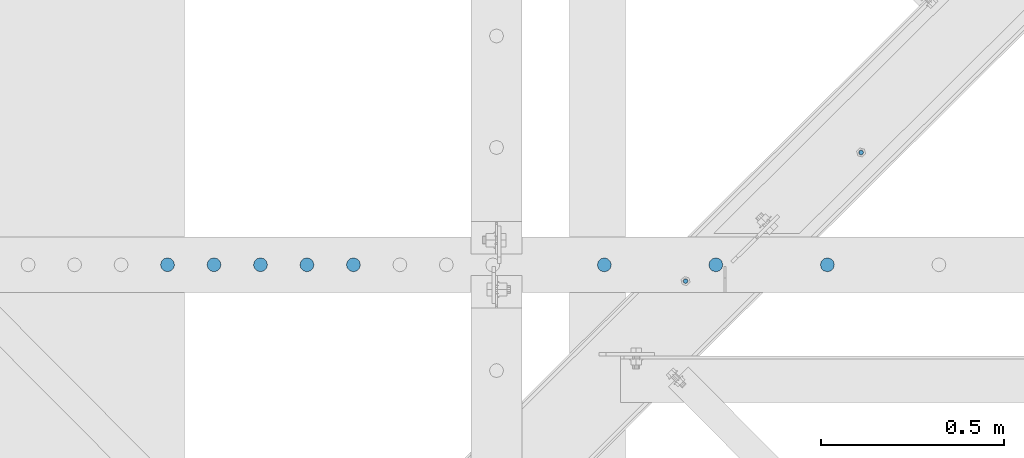
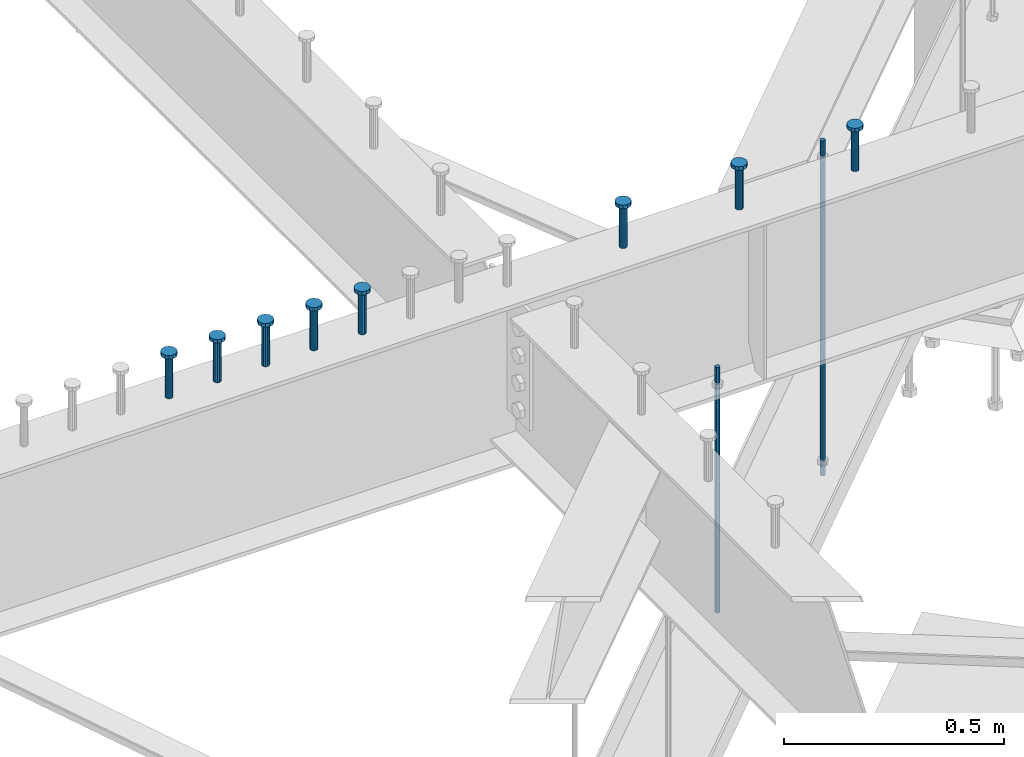
# One storey, part 207 of 975: 10 columns.
"""IFC2X3 building model written with IfcOpenShell, lengths in millimetres."""

from ifc_helpers import new_model, si_unit, frame, origin_with_axes, place, context, subcontext, project, spatial, faceted_brep, material, type_object, element, save


model = new_model("IFC2X3")

# Units and contexts
model_context = context("Model", 3, precision=1e-05, world=origin_with_axes())
body_context = subcontext(model_context, "Body", "Model", "MODEL_VIEW")
ifc_project = project(units=[si_unit("LENGTHUNIT", "METRE", prefix="MILLI"), si_unit("AREAUNIT", "SQUARE_METRE"), si_unit("VOLUMEUNIT", "CUBIC_METRE"), si_unit("MASSUNIT", "GRAM", prefix="KILO"), si_unit("TIMEUNIT", "SECOND"), si_unit("PLANEANGLEUNIT", "RADIAN"), si_unit("SOLIDANGLEUNIT", "STERADIAN"), si_unit("THERMODYNAMICTEMPERATUREUNIT", "DEGREE_CELSIUS"), si_unit("LUMINOUSINTENSITYUNIT", "LUMEN")], contexts=[model_context])

# Site, building, storey
site_placement = place(None, origin_with_axes())
site = spatial("IfcSite", under=ifc_project, at=site_placement, CompositionType="ELEMENT")
building_placement = place(site_placement, origin_with_axes())
building = spatial("IfcBuilding", under=site, at=building_placement, Name="Undefined", CompositionType="ELEMENT")
storey_placement = place(building_placement, origin_with_axes())
storey = spatial("IfcBuildingStorey", under=building, at=storey_placement, Name="Undefined", CompositionType="ELEMENT", Elevation=0.0)

# Columns
ifc_material_1 = material(Name="STEEL/A36")
column_type_1 = type_object("IfcColumnType", PredefinedType="NOTDEFINED")
column_1_placement = place(storey_placement, frame((27641.2127151628, 13699.1792456856, 2870.2), z_axis=(-0.705007718837806, 0.709199630836842, 0.0), x_axis=(0.0, 0.0, 1.0)))
element("IfcColumn", 1, at=column_1_placement, inside=storey, type_object=column_type_1, material=ifc_material_1, Name="ALL-THREAD ROD", context=body_context, shape_type="Brep", body=[
    faceted_brep([(0.0, -6.34999999998763, -3.63797880709171e-12), (0.0, -4.49012806052269, -4.49012806054634), (931.8625, -4.49012806052269, -4.49012806054634), (931.8625, -6.34999999998763, -3.63797880709171e-12), (0.0, 7.27595761418343e-12, -6.35000000000764), (931.8625, 7.27595761418343e-12, -6.35000000000764), (0.0, 4.49012806053724, -4.49012806053906), (931.8625, 4.49012806053724, -4.49012806053906), (0.0, 6.34999999999491, 5.45696821063757e-12), (931.8625, 6.34999999999491, 5.45696821063757e-12), (0.0, 4.49012806052633, 4.49012806054634), (931.8625, 4.49012806052633, 4.49012806054634), (0.0, 0.0, 6.35000000000764), (931.8625, 0.0, 6.35000000000764), (0.0, -4.49012806053361, 4.49012806053543), (931.8625, -4.49012806053361, 4.49012806053543)], [[[0, 1, 2, 3]], [[1, 4, 5, 2]], [[4, 6, 7, 5]], [[6, 8, 9, 7]], [[8, 10, 11, 9]], [[10, 12, 13, 11]], [[12, 14, 15, 13]], [[14, 0, 3, 15]], [[5, 7, 9, 11, 13, 15, 3, 2]], [[14, 12, 10, 8, 6, 4, 1, 0]]]),
])
column_2_placement = place(storey_placement, frame((27161.5007166304, 13347.70000005, 2870.2), z_axis=(-0.705007718837806, 0.709199630836842, 0.0), x_axis=(0.0, 0.0, 1.0)))
element("IfcColumn", 2, at=column_2_placement, inside=storey, type_object=column_type_1, material=ifc_material_1, Name="ALL-THREAD ROD", context=body_context, shape_type="Brep", body=[
    faceted_brep([(0.0, -6.34999999998763, -3.63797880709171e-12), (0.0, -4.49012806052269, -4.49012806054634), (682.625, -4.49012806052633, -4.49012806054816), (682.625, -6.34999999999491, -5.45696821063757e-12), (0.0, 7.27595761418343e-12, -6.35000000000764), (682.625, 7.27595761418343e-12, -6.35000000000764), (0.0, 4.49012806053724, -4.49012806053906), (682.625, 4.49012806053361, -4.49012806054088), (0.0, 6.34999999999491, 5.45696821063757e-12), (682.625, 6.34999999999127, 3.63797880709171e-12), (0.0, 4.49012806052633, 4.49012806054634), (682.625, 4.49012806052633, 4.49012806054634), (0.0, 0.0, 6.35000000000764), (682.625, -7.27595761418343e-12, 6.35000000000764), (0.0, -4.49012806053361, 4.49012806053543), (682.625, -4.49012806053361, 4.49012806053543)], [[[0, 1, 2, 3]], [[1, 4, 5, 2]], [[4, 6, 7, 5]], [[6, 8, 9, 7]], [[8, 10, 11, 9]], [[10, 12, 13, 11]], [[12, 14, 15, 13]], [[14, 0, 3, 15]], [[5, 7, 9, 11, 13, 15, 3, 2]], [[14, 12, 10, 8, 6, 4, 1, 0]]]),
])
ifc_material_2 = material(Name="STEEL/A108")
column_type_2 = type_object("IfcColumnType", Name="STUD_3/4-DIA", PredefinedType="NOTDEFINED")
column_3_placement = place(storey_placement, frame((27548.9459584101, 13392.15, 3937.0), z_axis=(0.0, 1.0, 0.0), x_axis=(0.0, 0.0, 1.0)))
element("IfcColumn", 3, at=column_3_placement, inside=storey, type_object=column_type_2, material=ifc_material_2, ObjectType="STUD_3/4-DIA", context=body_context, shape_type="Brep", body=[
    faceted_brep([(0.0, -9.52000045776367, 0.0), (0.0, -8.25, -4.76000022888184), (115.57, -8.25, -4.76000022888184), (115.57, -9.52000045776367, 0.0), (0.0, -4.76000022888184, -8.25), (115.57, -4.76000022888184, -8.25), (0.0, 0.0, -9.52000045776367), (115.57, 0.0, -9.52000045776367), (0.0, 4.76000022888184, -8.25), (115.57, 4.76000022888184, -8.25), (0.0, 8.25, -4.76000022888184), (115.57, 8.25, -4.76000022888184), (0.0, 9.52000045776367, 0.0), (115.57, 9.52000045776367, 0.0), (0.0, 8.25, 4.76000022888184), (115.57, 8.25, 4.76000022888184), (0.0, 4.76000022888184, 8.25), (115.57, 4.76000022888184, 8.25), (0.0, 0.0, 9.52000045776367), (115.57, 0.0, 9.52000045776367), (0.0, -4.76000022888184, 8.25), (115.57, -4.76000022888184, 8.25), (0.0, -8.25, 4.76000022888184), (115.57, -8.25, 4.76000022888184), (116.84, -16.5, -9.52000045776367), (116.84, -19.0499992370605, 0.0), (116.84, -9.52000045776367, -16.5), (116.84, 0.0, -19.0499992370605), (116.84, 9.52000045776367, -16.5), (116.84, 16.5, -9.52000045776367), (116.84, 19.0499992370605, 0.0), (116.84, 16.5, 9.52000045776367), (116.84, 9.52000045776367, 16.5), (116.84, 0.0, 19.0499992370605), (116.84, -9.52000045776367, 16.5), (116.84, -16.5, 9.52000045776367), (127.0, -16.5, -9.52000045776367), (127.0, -19.0499992370605, 0.0), (127.0, -9.52000045776367, -16.5), (127.0, 0.0, -19.0499992370605), (127.0, 9.52000045776367, -16.5), (127.0, 16.5, -9.52000045776367), (127.0, 19.0499992370605, 0.0), (127.0, 16.5, 9.52000045776367), (127.0, 9.52000045776367, 16.5), (127.0, 0.0, 19.0499992370605), (127.0, -9.52000045776367, 16.5), (127.0, -16.5, 9.52000045776367)], [[[0, 1, 2, 3]], [[1, 4, 5, 2]], [[4, 6, 7, 5]], [[6, 8, 9, 7]], [[8, 10, 11, 9]], [[10, 12, 13, 11]], [[12, 14, 15, 13]], [[14, 16, 17, 15]], [[16, 18, 19, 17]], [[18, 20, 21, 19]], [[20, 22, 23, 21]], [[22, 0, 3, 23]], [[22, 20, 18, 16, 14, 12, 10, 8, 6, 4, 1, 0]], [[3, 2, 24, 25]], [[2, 5, 26, 24]], [[5, 7, 27, 26]], [[7, 9, 28, 27]], [[9, 11, 29, 28]], [[11, 13, 30, 29]], [[13, 15, 31, 30]], [[15, 17, 32, 31]], [[17, 19, 33, 32]], [[19, 21, 34, 33]], [[21, 23, 35, 34]], [[23, 3, 25, 35]], [[25, 24, 36, 37]], [[24, 26, 38, 36]], [[26, 27, 39, 38]], [[27, 28, 40, 39]], [[28, 29, 41, 40]], [[29, 30, 42, 41]], [[30, 31, 43, 42]], [[31, 32, 44, 43]], [[32, 33, 45, 44]], [[33, 34, 46, 45]], [[34, 35, 47, 46]], [[35, 25, 37, 47]], [[38, 39, 40, 41, 42, 43, 44, 45, 46, 47, 37, 36]]]),
])
column_4_placement = place(storey_placement, frame((27244.1459584101, 13392.15, 3937.0), z_axis=(0.0, 1.0, 0.0), x_axis=(0.0, 0.0, 1.0)))
element("IfcColumn", 4, at=column_4_placement, inside=storey, type_object=column_type_2, material=ifc_material_2, ObjectType="STUD_3/4-DIA", context=body_context, shape_type="Brep", body=[
    faceted_brep([(0.0, -9.52000045776367, 0.0), (0.0, -8.25, -4.76000022888184), (115.57, -8.25, -4.76000022888184), (115.57, -9.52000045776367, 0.0), (0.0, -4.76000022888184, -8.25), (115.57, -4.76000022888184, -8.25), (0.0, 0.0, -9.52000045776367), (115.57, 0.0, -9.52000045776367), (0.0, 4.76000022888184, -8.25), (115.57, 4.76000022888184, -8.25), (0.0, 8.25, -4.76000022888184), (115.57, 8.25, -4.76000022888184), (0.0, 9.52000045776367, 0.0), (115.57, 9.52000045776367, 0.0), (0.0, 8.25, 4.76000022888184), (115.57, 8.25, 4.76000022888184), (0.0, 4.76000022888184, 8.25), (115.57, 4.76000022888184, 8.25), (0.0, 0.0, 9.52000045776367), (115.57, 0.0, 9.52000045776367), (0.0, -4.76000022888184, 8.25), (115.57, -4.76000022888184, 8.25), (0.0, -8.25, 4.76000022888184), (115.57, -8.25, 4.76000022888184), (116.84, -16.5, -9.52000045776367), (116.84, -19.0499992370605, 0.0), (116.84, -9.52000045776367, -16.5), (116.84, 0.0, -19.0499992370605), (116.84, 9.52000045776367, -16.5), (116.84, 16.5, -9.52000045776367), (116.84, 19.0499992370605, 0.0), (116.84, 16.5, 9.52000045776367), (116.84, 9.52000045776367, 16.5), (116.84, 0.0, 19.0499992370605), (116.84, -9.52000045776367, 16.5), (116.84, -16.5, 9.52000045776367), (127.0, -16.5, -9.52000045776367), (127.0, -19.0499992370605, 0.0), (127.0, -9.52000045776367, -16.5), (127.0, 0.0, -19.0499992370605), (127.0, 9.52000045776367, -16.5), (127.0, 16.5, -9.52000045776367), (127.0, 19.0499992370605, 0.0), (127.0, 16.5, 9.52000045776367), (127.0, 9.52000045776367, 16.5), (127.0, 0.0, 19.0499992370605), (127.0, -9.52000045776367, 16.5), (127.0, -16.5, 9.52000045776367)], [[[0, 1, 2, 3]], [[1, 4, 5, 2]], [[4, 6, 7, 5]], [[6, 8, 9, 7]], [[8, 10, 11, 9]], [[10, 12, 13, 11]], [[12, 14, 15, 13]], [[14, 16, 17, 15]], [[16, 18, 19, 17]], [[18, 20, 21, 19]], [[20, 22, 23, 21]], [[22, 0, 3, 23]], [[22, 20, 18, 16, 14, 12, 10, 8, 6, 4, 1, 0]], [[3, 2, 24, 25]], [[2, 5, 26, 24]], [[5, 7, 27, 26]], [[7, 9, 28, 27]], [[9, 11, 29, 28]], [[11, 13, 30, 29]], [[13, 15, 31, 30]], [[15, 17, 32, 31]], [[17, 19, 33, 32]], [[19, 21, 34, 33]], [[21, 23, 35, 34]], [[23, 3, 25, 35]], [[25, 24, 36, 37]], [[24, 26, 38, 36]], [[26, 27, 39, 38]], [[27, 28, 40, 39]], [[28, 29, 41, 40]], [[29, 30, 42, 41]], [[30, 31, 43, 42]], [[31, 32, 44, 43]], [[32, 33, 45, 44]], [[33, 34, 46, 45]], [[34, 35, 47, 46]], [[35, 25, 37, 47]], [[38, 39, 40, 41, 42, 43, 44, 45, 46, 47, 37, 36]]]),
])
column_5_placement = place(storey_placement, frame((26939.3459584101, 13392.15, 3937.0), z_axis=(0.0, 1.0, 0.0), x_axis=(0.0, 0.0, 1.0)))
element("IfcColumn", 5, at=column_5_placement, inside=storey, type_object=column_type_2, material=ifc_material_2, ObjectType="STUD_3/4-DIA", context=body_context, shape_type="Brep", body=[
    faceted_brep([(0.0, -9.52000045776367, 0.0), (0.0, -8.25, -4.76000022888184), (115.57, -8.25, -4.76000022888184), (115.57, -9.52000045776367, 0.0), (0.0, -4.76000022888184, -8.25), (115.57, -4.76000022888184, -8.25), (0.0, 0.0, -9.52000045776367), (115.57, 0.0, -9.52000045776367), (0.0, 4.76000022888184, -8.25), (115.57, 4.76000022888184, -8.25), (0.0, 8.25, -4.76000022888184), (115.57, 8.25, -4.76000022888184), (0.0, 9.52000045776367, 0.0), (115.57, 9.52000045776367, 0.0), (0.0, 8.25, 4.76000022888184), (115.57, 8.25, 4.76000022888184), (0.0, 4.76000022888184, 8.25), (115.57, 4.76000022888184, 8.25), (0.0, 0.0, 9.52000045776367), (115.57, 0.0, 9.52000045776367), (0.0, -4.76000022888184, 8.25), (115.57, -4.76000022888184, 8.25), (0.0, -8.25, 4.76000022888184), (115.57, -8.25, 4.76000022888184), (116.84, -16.5, -9.52000045776367), (116.84, -19.0499992370605, 0.0), (116.84, -9.52000045776367, -16.5), (116.84, 0.0, -19.0499992370605), (116.84, 9.52000045776367, -16.5), (116.84, 16.5, -9.52000045776367), (116.84, 19.0499992370605, 0.0), (116.84, 16.5, 9.52000045776367), (116.84, 9.52000045776367, 16.5), (116.84, 0.0, 19.0499992370605), (116.84, -9.52000045776367, 16.5), (116.84, -16.5, 9.52000045776367), (127.0, -16.5, -9.52000045776367), (127.0, -19.0499992370605, 0.0), (127.0, -9.52000045776367, -16.5), (127.0, 0.0, -19.0499992370605), (127.0, 9.52000045776367, -16.5), (127.0, 16.5, -9.52000045776367), (127.0, 19.0499992370605, 0.0), (127.0, 16.5, 9.52000045776367), (127.0, 9.52000045776367, 16.5), (127.0, 0.0, 19.0499992370605), (127.0, -9.52000045776367, 16.5), (127.0, -16.5, 9.52000045776367)], [[[0, 1, 2, 3]], [[1, 4, 5, 2]], [[4, 6, 7, 5]], [[6, 8, 9, 7]], [[8, 10, 11, 9]], [[10, 12, 13, 11]], [[12, 14, 15, 13]], [[14, 16, 17, 15]], [[16, 18, 19, 17]], [[18, 20, 21, 19]], [[20, 22, 23, 21]], [[22, 0, 3, 23]], [[22, 20, 18, 16, 14, 12, 10, 8, 6, 4, 1, 0]], [[3, 2, 24, 25]], [[2, 5, 26, 24]], [[5, 7, 27, 26]], [[7, 9, 28, 27]], [[9, 11, 29, 28]], [[11, 13, 30, 29]], [[13, 15, 31, 30]], [[15, 17, 32, 31]], [[17, 19, 33, 32]], [[19, 21, 34, 33]], [[21, 23, 35, 34]], [[23, 3, 25, 35]], [[25, 24, 36, 37]], [[24, 26, 38, 36]], [[26, 27, 39, 38]], [[27, 28, 40, 39]], [[28, 29, 41, 40]], [[29, 30, 42, 41]], [[30, 31, 43, 42]], [[31, 32, 44, 43]], [[32, 33, 45, 44]], [[33, 34, 46, 45]], [[34, 35, 47, 46]], [[35, 25, 37, 47]], [[38, 39, 40, 41, 42, 43, 44, 45, 46, 47, 37, 36]]]),
])
column_6_placement = place(storey_placement, frame((26253.5459584101, 13392.15, 3937.0), z_axis=(0.0, 1.0, 0.0), x_axis=(0.0, 0.0, 1.0)))
element("IfcColumn", 6, at=column_6_placement, inside=storey, type_object=column_type_2, material=ifc_material_2, ObjectType="STUD_3/4-DIA", context=body_context, shape_type="Brep", body=[
    faceted_brep([(0.0, -9.52000045776367, 0.0), (0.0, -8.25, -4.76000022888184), (115.57, -8.25, -4.76000022888184), (115.57, -9.52000045776367, 0.0), (0.0, -4.76000022888184, -8.25), (115.57, -4.76000022888184, -8.25), (0.0, 0.0, -9.52000045776367), (115.57, 0.0, -9.52000045776367), (0.0, 4.76000022888184, -8.25), (115.57, 4.76000022888184, -8.25), (0.0, 8.25, -4.76000022888184), (115.57, 8.25, -4.76000022888184), (0.0, 9.52000045776367, 0.0), (115.57, 9.52000045776367, 0.0), (0.0, 8.25, 4.76000022888184), (115.57, 8.25, 4.76000022888184), (0.0, 4.76000022888184, 8.25), (115.57, 4.76000022888184, 8.25), (0.0, 0.0, 9.52000045776367), (115.57, 0.0, 9.52000045776367), (0.0, -4.76000022888184, 8.25), (115.57, -4.76000022888184, 8.25), (0.0, -8.25, 4.76000022888184), (115.57, -8.25, 4.76000022888184), (116.84, -16.5, -9.52000045776367), (116.84, -19.0499992370605, 0.0), (116.84, -9.52000045776367, -16.5), (116.84, 0.0, -19.0499992370605), (116.84, 9.52000045776367, -16.5), (116.84, 16.5, -9.52000045776367), (116.84, 19.0499992370605, 0.0), (116.84, 16.5, 9.52000045776367), (116.84, 9.52000045776367, 16.5), (116.84, 0.0, 19.0499992370605), (116.84, -9.52000045776367, 16.5), (116.84, -16.5, 9.52000045776367), (127.0, -16.5, -9.52000045776367), (127.0, -19.0499992370605, 0.0), (127.0, -9.52000045776367, -16.5), (127.0, 0.0, -19.0499992370605), (127.0, 9.52000045776367, -16.5), (127.0, 16.5, -9.52000045776367), (127.0, 19.0499992370605, 0.0), (127.0, 16.5, 9.52000045776367), (127.0, 9.52000045776367, 16.5), (127.0, 0.0, 19.0499992370605), (127.0, -9.52000045776367, 16.5), (127.0, -16.5, 9.52000045776367)], [[[0, 1, 2, 3]], [[1, 4, 5, 2]], [[4, 6, 7, 5]], [[6, 8, 9, 7]], [[8, 10, 11, 9]], [[10, 12, 13, 11]], [[12, 14, 15, 13]], [[14, 16, 17, 15]], [[16, 18, 19, 17]], [[18, 20, 21, 19]], [[20, 22, 23, 21]], [[22, 0, 3, 23]], [[22, 20, 18, 16, 14, 12, 10, 8, 6, 4, 1, 0]], [[3, 2, 24, 25]], [[2, 5, 26, 24]], [[5, 7, 27, 26]], [[7, 9, 28, 27]], [[9, 11, 29, 28]], [[11, 13, 30, 29]], [[13, 15, 31, 30]], [[15, 17, 32, 31]], [[17, 19, 33, 32]], [[19, 21, 34, 33]], [[21, 23, 35, 34]], [[23, 3, 25, 35]], [[25, 24, 36, 37]], [[24, 26, 38, 36]], [[26, 27, 39, 38]], [[27, 28, 40, 39]], [[28, 29, 41, 40]], [[29, 30, 42, 41]], [[30, 31, 43, 42]], [[31, 32, 44, 43]], [[32, 33, 45, 44]], [[33, 34, 46, 45]], [[34, 35, 47, 46]], [[35, 25, 37, 47]], [[38, 39, 40, 41, 42, 43, 44, 45, 46, 47, 37, 36]]]),
])
column_7_placement = place(storey_placement, frame((26126.5459584101, 13392.15, 3937.0), z_axis=(0.0, 1.0, 0.0), x_axis=(0.0, 0.0, 1.0)))
element("IfcColumn", 7, at=column_7_placement, inside=storey, type_object=column_type_2, material=ifc_material_2, ObjectType="STUD_3/4-DIA", context=body_context, shape_type="Brep", body=[
    faceted_brep([(0.0, -9.52000045776367, 0.0), (0.0, -8.25, -4.76000022888184), (115.57, -8.25, -4.76000022888184), (115.57, -9.52000045776367, 0.0), (0.0, -4.76000022888184, -8.25), (115.57, -4.76000022888184, -8.25), (0.0, 0.0, -9.52000045776367), (115.57, 0.0, -9.52000045776367), (0.0, 4.76000022888184, -8.25), (115.57, 4.76000022888184, -8.25), (0.0, 8.25, -4.76000022888184), (115.57, 8.25, -4.76000022888184), (0.0, 9.52000045776367, 0.0), (115.57, 9.52000045776367, 0.0), (0.0, 8.25, 4.76000022888184), (115.57, 8.25, 4.76000022888184), (0.0, 4.76000022888184, 8.25), (115.57, 4.76000022888184, 8.25), (0.0, 0.0, 9.52000045776367), (115.57, 0.0, 9.52000045776367), (0.0, -4.76000022888184, 8.25), (115.57, -4.76000022888184, 8.25), (0.0, -8.25, 4.76000022888184), (115.57, -8.25, 4.76000022888184), (116.84, -16.5, -9.52000045776367), (116.84, -19.0499992370605, 0.0), (116.84, -9.52000045776367, -16.5), (116.84, 0.0, -19.0499992370605), (116.84, 9.52000045776367, -16.5), (116.84, 16.5, -9.52000045776367), (116.84, 19.0499992370605, 0.0), (116.84, 16.5, 9.52000045776367), (116.84, 9.52000045776367, 16.5), (116.84, 0.0, 19.0499992370605), (116.84, -9.52000045776367, 16.5), (116.84, -16.5, 9.52000045776367), (127.0, -16.5, -9.52000045776367), (127.0, -19.0499992370605, 0.0), (127.0, -9.52000045776367, -16.5), (127.0, 0.0, -19.0499992370605), (127.0, 9.52000045776367, -16.5), (127.0, 16.5, -9.52000045776367), (127.0, 19.0499992370605, 0.0), (127.0, 16.5, 9.52000045776367), (127.0, 9.52000045776367, 16.5), (127.0, 0.0, 19.0499992370605), (127.0, -9.52000045776367, 16.5), (127.0, -16.5, 9.52000045776367)], [[[0, 1, 2, 3]], [[1, 4, 5, 2]], [[4, 6, 7, 5]], [[6, 8, 9, 7]], [[8, 10, 11, 9]], [[10, 12, 13, 11]], [[12, 14, 15, 13]], [[14, 16, 17, 15]], [[16, 18, 19, 17]], [[18, 20, 21, 19]], [[20, 22, 23, 21]], [[22, 0, 3, 23]], [[22, 20, 18, 16, 14, 12, 10, 8, 6, 4, 1, 0]], [[3, 2, 24, 25]], [[2, 5, 26, 24]], [[5, 7, 27, 26]], [[7, 9, 28, 27]], [[9, 11, 29, 28]], [[11, 13, 30, 29]], [[13, 15, 31, 30]], [[15, 17, 32, 31]], [[17, 19, 33, 32]], [[19, 21, 34, 33]], [[21, 23, 35, 34]], [[23, 3, 25, 35]], [[25, 24, 36, 37]], [[24, 26, 38, 36]], [[26, 27, 39, 38]], [[27, 28, 40, 39]], [[28, 29, 41, 40]], [[29, 30, 42, 41]], [[30, 31, 43, 42]], [[31, 32, 44, 43]], [[32, 33, 45, 44]], [[33, 34, 46, 45]], [[34, 35, 47, 46]], [[35, 25, 37, 47]], [[38, 39, 40, 41, 42, 43, 44, 45, 46, 47, 37, 36]]]),
])
column_8_placement = place(storey_placement, frame((25999.5459584101, 13392.15, 3937.0), z_axis=(0.0, 1.0, 0.0), x_axis=(0.0, 0.0, 1.0)))
element("IfcColumn", 8, at=column_8_placement, inside=storey, type_object=column_type_2, material=ifc_material_2, ObjectType="STUD_3/4-DIA", context=body_context, shape_type="Brep", body=[
    faceted_brep([(0.0, -9.52000045776367, 0.0), (0.0, -8.25, -4.76000022888184), (115.57, -8.25, -4.76000022888184), (115.57, -9.52000045776367, 0.0), (0.0, -4.76000022888184, -8.25), (115.57, -4.76000022888184, -8.25), (0.0, 0.0, -9.52000045776367), (115.57, 0.0, -9.52000045776367), (0.0, 4.76000022888184, -8.25), (115.57, 4.76000022888184, -8.25), (0.0, 8.25, -4.76000022888184), (115.57, 8.25, -4.76000022888184), (0.0, 9.52000045776367, 0.0), (115.57, 9.52000045776367, 0.0), (0.0, 8.25, 4.76000022888184), (115.57, 8.25, 4.76000022888184), (0.0, 4.76000022888184, 8.25), (115.57, 4.76000022888184, 8.25), (0.0, 0.0, 9.52000045776367), (115.57, 0.0, 9.52000045776367), (0.0, -4.76000022888184, 8.25), (115.57, -4.76000022888184, 8.25), (0.0, -8.25, 4.76000022888184), (115.57, -8.25, 4.76000022888184), (116.84, -16.5, -9.52000045776367), (116.84, -19.0499992370605, 0.0), (116.84, -9.52000045776367, -16.5), (116.84, 0.0, -19.0499992370605), (116.84, 9.52000045776367, -16.5), (116.84, 16.5, -9.52000045776367), (116.84, 19.0499992370605, 0.0), (116.84, 16.5, 9.52000045776367), (116.84, 9.52000045776367, 16.5), (116.84, 0.0, 19.0499992370605), (116.84, -9.52000045776367, 16.5), (116.84, -16.5, 9.52000045776367), (127.0, -16.5, -9.52000045776367), (127.0, -19.0499992370605, 0.0), (127.0, -9.52000045776367, -16.5), (127.0, 0.0, -19.0499992370605), (127.0, 9.52000045776367, -16.5), (127.0, 16.5, -9.52000045776367), (127.0, 19.0499992370605, 0.0), (127.0, 16.5, 9.52000045776367), (127.0, 9.52000045776367, 16.5), (127.0, 0.0, 19.0499992370605), (127.0, -9.52000045776367, 16.5), (127.0, -16.5, 9.52000045776367)], [[[0, 1, 2, 3]], [[1, 4, 5, 2]], [[4, 6, 7, 5]], [[6, 8, 9, 7]], [[8, 10, 11, 9]], [[10, 12, 13, 11]], [[12, 14, 15, 13]], [[14, 16, 17, 15]], [[16, 18, 19, 17]], [[18, 20, 21, 19]], [[20, 22, 23, 21]], [[22, 0, 3, 23]], [[22, 20, 18, 16, 14, 12, 10, 8, 6, 4, 1, 0]], [[3, 2, 24, 25]], [[2, 5, 26, 24]], [[5, 7, 27, 26]], [[7, 9, 28, 27]], [[9, 11, 29, 28]], [[11, 13, 30, 29]], [[13, 15, 31, 30]], [[15, 17, 32, 31]], [[17, 19, 33, 32]], [[19, 21, 34, 33]], [[21, 23, 35, 34]], [[23, 3, 25, 35]], [[25, 24, 36, 37]], [[24, 26, 38, 36]], [[26, 27, 39, 38]], [[27, 28, 40, 39]], [[28, 29, 41, 40]], [[29, 30, 42, 41]], [[30, 31, 43, 42]], [[31, 32, 44, 43]], [[32, 33, 45, 44]], [[33, 34, 46, 45]], [[34, 35, 47, 46]], [[35, 25, 37, 47]], [[38, 39, 40, 41, 42, 43, 44, 45, 46, 47, 37, 36]]]),
])
column_9_placement = place(storey_placement, frame((25872.5459584101, 13392.15, 3937.0), z_axis=(0.0, 1.0, 0.0), x_axis=(0.0, 0.0, 1.0)))
element("IfcColumn", 9, at=column_9_placement, inside=storey, type_object=column_type_2, material=ifc_material_2, ObjectType="STUD_3/4-DIA", context=body_context, shape_type="Brep", body=[
    faceted_brep([(0.0, -9.52000045776367, 0.0), (0.0, -8.25, -4.76000022888184), (115.57, -8.25, -4.76000022888184), (115.57, -9.52000045776367, 0.0), (0.0, -4.76000022888184, -8.25), (115.57, -4.76000022888184, -8.25), (0.0, 0.0, -9.52000045776367), (115.57, 0.0, -9.52000045776367), (0.0, 4.76000022888184, -8.25), (115.57, 4.76000022888184, -8.25), (0.0, 8.25, -4.76000022888184), (115.57, 8.25, -4.76000022888184), (0.0, 9.52000045776367, 0.0), (115.57, 9.52000045776367, 0.0), (0.0, 8.25, 4.76000022888184), (115.57, 8.25, 4.76000022888184), (0.0, 4.76000022888184, 8.25), (115.57, 4.76000022888184, 8.25), (0.0, 0.0, 9.52000045776367), (115.57, 0.0, 9.52000045776367), (0.0, -4.76000022888184, 8.25), (115.57, -4.76000022888184, 8.25), (0.0, -8.25, 4.76000022888184), (115.57, -8.25, 4.76000022888184), (116.84, -16.5, -9.52000045776367), (116.84, -19.0499992370605, 0.0), (116.84, -9.52000045776367, -16.5), (116.84, 0.0, -19.0499992370605), (116.84, 9.52000045776367, -16.5), (116.84, 16.5, -9.52000045776367), (116.84, 19.0499992370605, 0.0), (116.84, 16.5, 9.52000045776367), (116.84, 9.52000045776367, 16.5), (116.84, 0.0, 19.0499992370605), (116.84, -9.52000045776367, 16.5), (116.84, -16.5, 9.52000045776367), (127.0, -16.5, -9.52000045776367), (127.0, -19.0499992370605, 0.0), (127.0, -9.52000045776367, -16.5), (127.0, 0.0, -19.0499992370605), (127.0, 9.52000045776367, -16.5), (127.0, 16.5, -9.52000045776367), (127.0, 19.0499992370605, 0.0), (127.0, 16.5, 9.52000045776367), (127.0, 9.52000045776367, 16.5), (127.0, 0.0, 19.0499992370605), (127.0, -9.52000045776367, 16.5), (127.0, -16.5, 9.52000045776367)], [[[0, 1, 2, 3]], [[1, 4, 5, 2]], [[4, 6, 7, 5]], [[6, 8, 9, 7]], [[8, 10, 11, 9]], [[10, 12, 13, 11]], [[12, 14, 15, 13]], [[14, 16, 17, 15]], [[16, 18, 19, 17]], [[18, 20, 21, 19]], [[20, 22, 23, 21]], [[22, 0, 3, 23]], [[22, 20, 18, 16, 14, 12, 10, 8, 6, 4, 1, 0]], [[3, 2, 24, 25]], [[2, 5, 26, 24]], [[5, 7, 27, 26]], [[7, 9, 28, 27]], [[9, 11, 29, 28]], [[11, 13, 30, 29]], [[13, 15, 31, 30]], [[15, 17, 32, 31]], [[17, 19, 33, 32]], [[19, 21, 34, 33]], [[21, 23, 35, 34]], [[23, 3, 25, 35]], [[25, 24, 36, 37]], [[24, 26, 38, 36]], [[26, 27, 39, 38]], [[27, 28, 40, 39]], [[28, 29, 41, 40]], [[29, 30, 42, 41]], [[30, 31, 43, 42]], [[31, 32, 44, 43]], [[32, 33, 45, 44]], [[33, 34, 46, 45]], [[34, 35, 47, 46]], [[35, 25, 37, 47]], [[38, 39, 40, 41, 42, 43, 44, 45, 46, 47, 37, 36]]]),
])
column_10_placement = place(storey_placement, frame((25745.5459584101, 13392.15, 3937.0), z_axis=(0.0, 1.0, 0.0), x_axis=(0.0, 0.0, 1.0)))
element("IfcColumn", 10, at=column_10_placement, inside=storey, type_object=column_type_2, material=ifc_material_2, ObjectType="STUD_3/4-DIA", context=body_context, shape_type="Brep", body=[
    faceted_brep([(0.0, -9.52000045776367, 0.0), (0.0, -8.25, -4.76000022888184), (115.57, -8.25, -4.76000022888184), (115.57, -9.52000045776367, 0.0), (0.0, -4.76000022888184, -8.25), (115.57, -4.76000022888184, -8.25), (0.0, 0.0, -9.52000045776367), (115.57, 0.0, -9.52000045776367), (0.0, 4.76000022888184, -8.25), (115.57, 4.76000022888184, -8.25), (0.0, 8.25, -4.76000022888184), (115.57, 8.25, -4.76000022888184), (0.0, 9.52000045776367, 0.0), (115.57, 9.52000045776367, 0.0), (0.0, 8.25, 4.76000022888184), (115.57, 8.25, 4.76000022888184), (0.0, 4.76000022888184, 8.25), (115.57, 4.76000022888184, 8.25), (0.0, 0.0, 9.52000045776367), (115.57, 0.0, 9.52000045776367), (0.0, -4.76000022888184, 8.25), (115.57, -4.76000022888184, 8.25), (0.0, -8.25, 4.76000022888184), (115.57, -8.25, 4.76000022888184), (116.84, -16.5, -9.52000045776367), (116.84, -19.0499992370605, 0.0), (116.84, -9.52000045776367, -16.5), (116.84, 0.0, -19.0499992370605), (116.84, 9.52000045776367, -16.5), (116.84, 16.5, -9.52000045776367), (116.84, 19.0499992370605, 0.0), (116.84, 16.5, 9.52000045776367), (116.84, 9.52000045776367, 16.5), (116.84, 0.0, 19.0499992370605), (116.84, -9.52000045776367, 16.5), (116.84, -16.5, 9.52000045776367), (127.0, -16.5, -9.52000045776367), (127.0, -19.0499992370605, 0.0), (127.0, -9.52000045776367, -16.5), (127.0, 0.0, -19.0499992370605), (127.0, 9.52000045776367, -16.5), (127.0, 16.5, -9.52000045776367), (127.0, 19.0499992370605, 0.0), (127.0, 16.5, 9.52000045776367), (127.0, 9.52000045776367, 16.5), (127.0, 0.0, 19.0499992370605), (127.0, -9.52000045776367, 16.5), (127.0, -16.5, 9.52000045776367)], [[[0, 1, 2, 3]], [[1, 4, 5, 2]], [[4, 6, 7, 5]], [[6, 8, 9, 7]], [[8, 10, 11, 9]], [[10, 12, 13, 11]], [[12, 14, 15, 13]], [[14, 16, 17, 15]], [[16, 18, 19, 17]], [[18, 20, 21, 19]], [[20, 22, 23, 21]], [[22, 0, 3, 23]], [[22, 20, 18, 16, 14, 12, 10, 8, 6, 4, 1, 0]], [[3, 2, 24, 25]], [[2, 5, 26, 24]], [[5, 7, 27, 26]], [[7, 9, 28, 27]], [[9, 11, 29, 28]], [[11, 13, 30, 29]], [[13, 15, 31, 30]], [[15, 17, 32, 31]], [[17, 19, 33, 32]], [[19, 21, 34, 33]], [[21, 23, 35, 34]], [[23, 3, 25, 35]], [[25, 24, 36, 37]], [[24, 26, 38, 36]], [[26, 27, 39, 38]], [[27, 28, 40, 39]], [[28, 29, 41, 40]], [[29, 30, 42, 41]], [[30, 31, 43, 42]], [[31, 32, 44, 43]], [[32, 33, 45, 44]], [[33, 34, 46, 45]], [[34, 35, 47, 46]], [[35, 25, 37, 47]], [[38, 39, 40, 41, 42, 43, 44, 45, 46, 47, 37, 36]]]),
])

save(model, "model.ifc")
